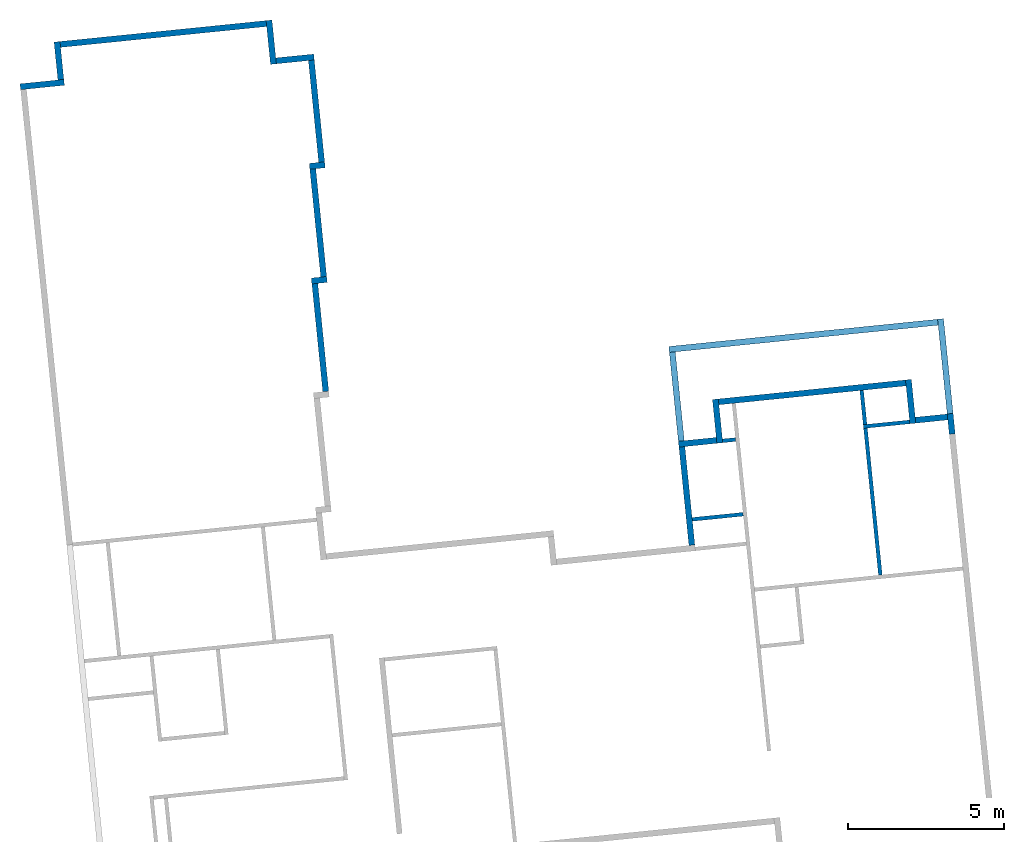
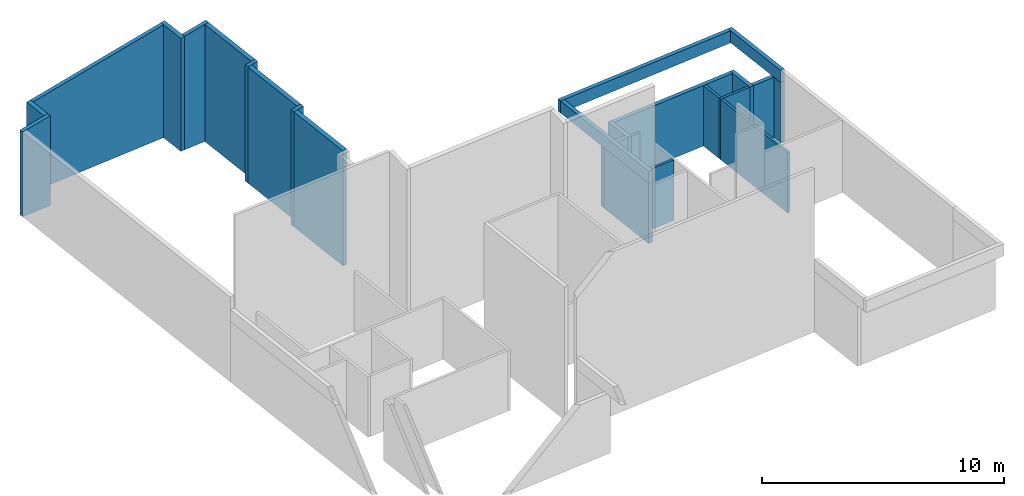
# One storey, part 2 of 2: 25 walls.
"""IFC2X3 building model written with IfcOpenShell, lengths in feet."""

from ifc_helpers import new_model, entity, si_unit, converted_unit, derived_unit, direction, frame, frame_2d, origin, place, context, subcontext, project, spatial, polyline, rectangle, extrude, clip, bounded_halfspace, material, layer, layer_set, layer_usage, type_object, element, save


model = new_model("IFC2X3")

# Units and contexts
model_context = context("Model", 3, precision=0.0001, world=origin(), true_north=direction((0.100810849702482, 0.994905609885814)))
body_context = subcontext(model_context, "Body", "Model", "MODEL_VIEW")
ifc_project = project(units=[converted_unit("LENGTHUNIT", "FOOT", entity("IfcRatioMeasure", 0.3048), si_unit("LENGTHUNIT", "METRE"), dimensions=[1, 0, 0, 0, 0, 0, 0]), converted_unit("AREAUNIT", "SQUARE FOOT", entity("IfcRatioMeasure", 0.09290304), si_unit("AREAUNIT", "SQUARE_METRE"), dimensions=[2, 0, 0, 0, 0, 0, 0]), converted_unit("VOLUMEUNIT", "CUBIC FOOT", entity("IfcRatioMeasure", 0.028316846592), si_unit("VOLUMEUNIT", "CUBIC_METRE"), dimensions=[3, 0, 0, 0, 0, 0, 0]), converted_unit("PLANEANGLEUNIT", "DEGREE", entity("IfcRatioMeasure", 0.0174532925199433), si_unit("PLANEANGLEUNIT", "RADIAN"), dimensions=[0, 0, 0, 0, 0, 0, 0]), si_unit("MASSUNIT", "GRAM", prefix="KILO"), derived_unit("MASSDENSITYUNIT", [(si_unit("MASSUNIT", "GRAM", prefix="KILO"), 1), (si_unit("LENGTHUNIT", "METRE"), -3)]), si_unit("TIMEUNIT", "SECOND"), si_unit("FREQUENCYUNIT", "HERTZ"), si_unit("THERMODYNAMICTEMPERATUREUNIT", "DEGREE_CELSIUS"), derived_unit("THERMALTRANSMITTANCEUNIT", [(si_unit("MASSUNIT", "GRAM", prefix="KILO"), 1), (si_unit("THERMODYNAMICTEMPERATUREUNIT", "KELVIN"), -1), (si_unit("TIMEUNIT", "SECOND"), -3)]), derived_unit("VOLUMETRICFLOWRATEUNIT", [(si_unit("LENGTHUNIT", "METRE"), 3), (si_unit("TIMEUNIT", "SECOND"), -1)]), si_unit("ELECTRICCURRENTUNIT", "AMPERE"), si_unit("ELECTRICVOLTAGEUNIT", "VOLT"), si_unit("POWERUNIT", "WATT"), si_unit("FORCEUNIT", "NEWTON"), si_unit("ILLUMINANCEUNIT", "LUX"), si_unit("LUMINOUSFLUXUNIT", "LUMEN"), si_unit("LUMINOUSINTENSITYUNIT", "CANDELA"), derived_unit("USERDEFINED", [(si_unit("MASSUNIT", "GRAM", prefix="KILO"), -1), (si_unit("LENGTHUNIT", "METRE"), -2), (si_unit("TIMEUNIT", "SECOND"), 3), (si_unit("LUMINOUSFLUXUNIT", "LUMEN"), 1)]), derived_unit("LINEARVELOCITYUNIT", [(si_unit("LENGTHUNIT", "METRE"), 1), (si_unit("TIMEUNIT", "SECOND"), -1)]), si_unit("PRESSUREUNIT", "PASCAL"), derived_unit("USERDEFINED", [(si_unit("LENGTHUNIT", "METRE"), -2), (si_unit("MASSUNIT", "GRAM", prefix="KILO"), 1), (si_unit("TIMEUNIT", "SECOND"), -2)])], contexts=[model_context])

# Site, building, storey
site_placement = place(None, frame((124.447249452883, 13.3868691254093, 0.0), z_axis=(0.0, 0.0, 1.0), x_axis=(0.994905609885814, 0.100810849702482, 0.0)))
site = spatial("IfcSite", under=ifc_project, at=site_placement, CompositionType="ELEMENT")
building_placement = place(site_placement, origin())
building = spatial("IfcBuilding", under=site, at=building_placement, CompositionType="ELEMENT")
storey_placement = place(building_placement, origin())
storey = spatial("IfcBuildingStorey", under=building, at=storey_placement, Name="First Floor", CompositionType="ELEMENT", Elevation=0.0)

# Walls
ifc_material_1 = material(Name="Stucco")
ifc_layer_1 = layer(ifc_material_1, 0.0729166666666667)
ifc_material_2 = material(Name="Plywood, Sheathing")
ifc_layer_2 = layer(ifc_material_2, 0.0416666666666667)
ifc_material_3 = material(Name="Softwood, Lumber")
ifc_layer_3 = layer(ifc_material_3, 0.458333333333333)
ifc_material_4 = material(Name="Gypsum Wall Board")
ifc_layer_4 = layer(ifc_material_4, 0.0520833333333333)
ifc_layer_set_1 = layer_set([ifc_layer_1, ifc_layer_2, ifc_layer_3, ifc_layer_4])
ifc_layer_usage_1 = layer_usage(ifc_layer_set_1, "AXIS2", "NEGATIVE", 0.3125)
wall_type_1 = type_object("IfcWallType", PredefinedType="STANDARD", material=ifc_layer_set_1)
wall_1_placement = place(storey_placement, frame((-30.5287863546898, -65.576981392437, 0.0)))
element("IfcWallStandardCase", 1, at=wall_1_placement, inside=storey, type_object=wall_type_1, material=ifc_layer_usage_1, Name="Basic Wall:Exterior - Stucco (light) on Wood Stud", context=body_context, shape_type="Clipping", body=[
    clip(extrude(rectangle(XDim=4.62500000000005, YDim=0.625, at=frame_2d((2.31250000000003, 1.11022302462516e-15), x_axis=(-1.0, 0.0))), origin(), (0.0, 0.0, 1.0), 14.8155898172751), bounded_halfspace(frame((0.0, -0.3125, 14.0000775315002), z_axis=(0.173648177666572, 0.0, -0.984807753012271), x_axis=(0.0, -1.0, 0.0)), True, frame((0.0, -0.3125, 14.0000775315002)), polyline([(0.0, 0.0), (0.625, 0.0), (4.62500000000005, 0.0), (4.62500000000005, 0.625000000000014), (4.0, 0.625), (0.0, 0.625), (0.0, 0.0)]))),
])
ifc_layer_usage_2 = layer_usage(ifc_layer_set_1, "AXIS2", "NEGATIVE", 0.3125)
wall_2_placement = place(storey_placement, frame((-26.2162863546897, -65.264481392437, 0.0), z_axis=(0.0, 0.0, 1.0), x_axis=(0.0, 1.0, 0.0)))
element("IfcWallStandardCase", 2, at=wall_2_placement, inside=storey, type_object=wall_type_1, material=ifc_layer_usage_2, Name="Basic Wall:Exterior - Stucco (light) on Wood Stud", context=body_context, shape_type="Clipping", body=[
    clip(extrude(rectangle(XDim=4.0, YDim=0.625, at=frame_2d((2.0, 0.0), x_axis=(-1.0, 0.0))), origin(), (0.0, 0.0, 1.0), 14.8155898172752), bounded_halfspace(frame((0.0, -0.3125, 14.8155898172751), z_axis=(0.0, -0.173648177666572, -0.984807753012271), x_axis=(-1.0, 0.0, 0.0)), True, frame((0.0, -0.3125, 14.8155898172751)), polyline([(0.0, 0.0), (3.375, 0.0), (4.0, 0.0), (4.0, 0.625), (0.0, 0.625), (0.0, 0.0)]))),
])
ifc_layer_usage_3 = layer_usage(ifc_layer_set_1, "AXIS2", "NEGATIVE", 0.3125)
wall_3_placement = place(storey_placement, frame((-3.84128635468974, -61.2644813924371, 0.0), z_axis=(0.0, 0.0, 1.0), x_axis=(0.0, -1.0, 0.0)))
element("IfcWallStandardCase", 3, at=wall_3_placement, inside=storey, type_object=wall_type_1, material=ifc_layer_usage_3, Name="Basic Wall:Exterior - Stucco (light) on Wood Stud", context=body_context, shape_type="Clipping", body=[
    clip(extrude(rectangle(XDim=4.62500000000001, YDim=0.625, at=frame_2d((2.31250000000001, 0.0), x_axis=(-1.0, 0.0))), origin(), (0.0, 0.0, 1.0), 18.7609060106187), bounded_halfspace(frame((0.0, -0.3125, 18.6507016476762), z_axis=(0.0, 0.173648177666572, -0.984807753012271), x_axis=(1.0, 0.0, 0.0)), True, frame((0.0, -0.3125, 18.6507016476762)), polyline([(0.0, 0.0), (0.625, 0.0), (4.62500000000001, 0.0), (4.62500000000001, 0.625), (4.0, 0.625), (0.0, 0.625), (0.0, 0.0)]))),
])
ifc_layer_usage_4 = layer_usage(ifc_layer_set_1, "AXIS2", "NEGATIVE", 0.3125)
wall_4_placement = place(storey_placement, frame((-3.52878635468974, -65.5769813924371, 0.0)))
element("IfcWallStandardCase", 4, at=wall_4_placement, inside=storey, type_object=wall_type_1, material=ifc_layer_usage_4, Name="Basic Wall:Exterior - Stucco (light) on Wood Stud", context=body_context, shape_type="Clipping", body=[
    clip(extrude(rectangle(XDim=4.0, YDim=0.625, at=frame_2d((2.0, 0.0), x_axis=(-1.0, 0.0))), origin(), (0.0, 0.0, 1.0), 19.466213933451), bounded_halfspace(frame((0.0, -0.3125, 18.7609060106186), z_axis=(0.173648177666572, 0.0, -0.984807753012271), x_axis=(0.0, -1.0, 0.0)), True, frame((0.0, -0.3125, 18.7609060106186)), polyline([(0.0, 0.0), (3.375, 0.0), (4.0, 0.0), (4.0, 0.625), (0.0, 0.625), (0.0, 0.0)]))),
])
ifc_layer_usage_5 = layer_usage(ifc_layer_set_1, "AXIS2", "NEGATIVE", 0.3125)
wall_5_placement = place(storey_placement, frame((0.158713645310257, -65.8894813924371, 0.0), z_axis=(0.0, 0.0, 1.0), x_axis=(0.0, -1.0, 0.0)))
element("IfcWallStandardCase", 5, at=wall_5_placement, inside=storey, type_object=wall_type_1, material=ifc_layer_usage_5, Name="Basic Wall:Exterior - Stucco (light) on Wood Stud", context=body_context, shape_type="Clipping", body=[
    clip(extrude(rectangle(XDim=10.75, YDim=0.625, at=frame_2d((5.375, 0.0), x_axis=(-1.0, 0.0))), origin(), (0.0, 0.0, 1.0), 19.466213933451), bounded_halfspace(frame((0.0, -0.3125, 19.3560095705084), z_axis=(0.0, 0.173648177666572, -0.984807753012271), x_axis=(1.0, 0.0, 0.0)), True, frame((0.0, -0.3125, 19.3560095705084)), polyline([(0.0, 0.0), (10.75, 0.0), (10.75, 0.625), (0.0, 0.625), (0.0, 0.0)]))),
])
ifc_layer_usage_6 = layer_usage(ifc_layer_set_1, "AXIS2", "NEGATIVE", 0.3125)
wall_6_placement = place(storey_placement, frame((0.471213645310257, -76.9519813924371, 0.0), z_axis=(0.0, 0.0, 1.0), x_axis=(-1.0, 0.0, 0.0)))
element("IfcWallStandardCase", 6, at=wall_6_placement, inside=storey, type_object=wall_type_1, material=ifc_layer_usage_6, Name="Basic Wall:Exterior - Stucco (light) on Wood Stud", context=body_context, shape_type="Clipping", body=[
    clip(extrude(rectangle(XDim=1.625, YDim=0.625, at=frame_2d((0.8125, 0.0), x_axis=(-1.0, 0.0))), origin(), (0.0, 0.0, 1.0), 19.4662139334508), bounded_halfspace(frame((0.0, -0.3125, 19.4662139334508), z_axis=(-0.173648177666572, 0.0, -0.984807753012271), x_axis=(0.0, 1.0, 0.0)), True, frame((0.0, -0.3125, 19.4662139334508)), polyline([(0.0, 0.0), (0.625, 0.0), (1.625, 0.0), (1.625, 0.625), (1.0, 0.625), (0.0, 0.625), (0.0, 0.0)]))),
])
ifc_layer_usage_7 = layer_usage(ifc_layer_set_1, "AXIS2", "NEGATIVE", 0.3125)
wall_7_placement = place(storey_placement, frame((-0.841286354689743, -77.2644813924371, 0.0), z_axis=(0.0, 0.0, 1.0), x_axis=(0.0, -1.0, 0.0)))
element("IfcWallStandardCase", 7, at=wall_7_placement, inside=storey, type_object=wall_type_1, material=ifc_layer_usage_7, Name="Basic Wall:Exterior - Stucco (light) on Wood Stud", context=body_context, shape_type="Clipping", body=[
    clip(extrude(rectangle(XDim=11.375, YDim=0.625, at=frame_2d((5.6875, 0.0), x_axis=(-1.0, 0.0))), origin(), (0.0, 0.0, 1.0), 19.2898869527427), bounded_halfspace(frame((0.0, -0.3125, 19.1796825898002), z_axis=(0.0, 0.173648177666572, -0.984807753012271), x_axis=(1.0, 0.0, 0.0)), True, frame((0.0, -0.3125, 19.1796825898002)), polyline([(0.0, 0.0), (11.375, 0.0), (11.375, 0.625), (0.0, 0.625), (0.0, 0.0)]))),
])
ifc_layer_usage_8 = layer_usage(ifc_layer_set_1, "AXIS2", "NEGATIVE", 0.3125)
wall_8_placement = place(storey_placement, frame((-0.528786354689743, -88.9519813924371, 0.0), z_axis=(0.0, 0.0, 1.0), x_axis=(-1.0, 0.0, 0.0)))
element("IfcWallStandardCase", 8, at=wall_8_placement, inside=storey, type_object=wall_type_1, material=ifc_layer_usage_8, Name="Basic Wall:Exterior - Stucco (light) on Wood Stud", context=body_context, shape_type="Clipping", body=[
    clip(extrude(rectangle(XDim=1.625, YDim=0.625, at=frame_2d((0.8125, 0.0), x_axis=(-1.0, 0.0))), origin(), (0.0, 0.0, 1.0), 19.2898869527425), bounded_halfspace(frame((0.0, -0.3125, 19.2898869527425), z_axis=(-0.173648177666572, 0.0, -0.984807753012271), x_axis=(0.0, 1.0, 0.0)), True, frame((0.0, -0.3125, 19.2898869527425)), polyline([(0.0, 0.0), (0.625, 0.0), (1.625, 0.0), (1.625, 0.625), (1.0, 0.625), (0.0, 0.625), (0.0, 0.0)]))),
])
ifc_layer_usage_9 = layer_usage(ifc_layer_set_1, "AXIS2", "NEGATIVE", 0.3125)
wall_9_placement = place(storey_placement, frame((-1.84128635468974, -89.2644813924371, 0.0), z_axis=(0.0, 0.0, 1.0), x_axis=(0.0, -1.0, 0.0)))
element("IfcWallStandardCase", 9, at=wall_9_placement, inside=storey, type_object=wall_type_1, material=ifc_layer_usage_9, Name="Basic Wall:Exterior - Stucco (light) on Wood Stud", context=body_context, shape_type="Clipping", body=[
    clip(extrude(rectangle(XDim=11.375, YDim=0.625, at=frame_2d((5.6875, 0.0), x_axis=(-1.0, 0.0))), origin(), (0.0, 0.0, 1.0), 19.1135599720344), bounded_halfspace(frame((0.0, -0.3125, 19.0033556090919), z_axis=(0.0, 0.173648177666572, -0.984807753012271), x_axis=(1.0, 0.0, 0.0)), True, frame((0.0, -0.3125, 19.0033556090919)), polyline([(0.0, 0.0), (11.375, 0.0), (11.375, 0.625), (0.0, 0.625), (0.0, 0.0)]))),
])
ifc_layer_usage_10 = layer_usage(ifc_layer_set_1, "AXIS2", "NEGATIVE", 0.3125)
wall_10_placement = place(storey_placement, frame((38.7836969786436, -110.201981392437, 0.0), z_axis=(0.0, 0.0, 1.0), x_axis=(0.0, 1.0, 0.0)))
element("IfcWallStandardCase", 10, at=wall_10_placement, inside=storey, type_object=wall_type_1, material=ifc_layer_usage_10, Name="Basic Wall:Exterior - Stucco (light) on Wood Stud", context=body_context, shape_type="SweptSolid", body=[
    extrude(rectangle(XDim=4.625, YDim=0.625, at=frame_2d((2.3125, 0.0), x_axis=(-1.0, 0.0))), origin(), (0.0, 0.0, 1.0), 10.0),
])
ifc_layer_usage_11 = layer_usage(ifc_layer_set_1, "AXIS2", "NEGATIVE", 0.3125)
wall_11_placement = place(storey_placement, frame((59.1587136453103, -105.576981392437, 0.0), z_axis=(0.0, 0.0, 1.0), x_axis=(0.0, -1.0, 0.0)))
element("IfcWallStandardCase", 11, at=wall_11_placement, inside=storey, type_object=wall_type_1, material=ifc_layer_usage_11, Name="Basic Wall:Exterior - Stucco (light) on Wood Stud", context=body_context, shape_type="SweptSolid", body=[
    extrude(rectangle(XDim=4.62499999999999, YDim=0.625, at=frame_2d((2.31249999999999, 5.55111512312578e-16), x_axis=(-1.0, 0.0))), origin(), (0.0, 0.0, 1.0), 10.0),
])
ifc_layer_usage_12 = layer_usage(ifc_layer_set_1, "AXIS2", "NEGATIVE", 0.3125)
wall_12_placement = place(storey_placement, frame((-25.9037863546897, -61.576981392437, 0.0)))
element("IfcWallStandardCase", 12, at=wall_12_placement, inside=storey, type_object=wall_type_1, material=ifc_layer_usage_12, Name="Basic Wall:Exterior - Stucco (light) on Wood Stud", context=body_context, shape_type="Clipping", body=[
    clip(extrude(rectangle(XDim=21.75, YDim=0.625, at=frame_2d((10.875, -1.94289029309402e-15), x_axis=(-1.0, 0.0))), origin(), (0.0, 0.0, 1.0), 18.6507016476762), bounded_halfspace(frame((0.0, -0.3125, 14.8155898172752), z_axis=(0.173648177666572, 0.0, -0.984807753012271), x_axis=(0.0, -1.0, 0.0)), True, frame((0.0, -0.3125, 14.8155898172752)), polyline([(0.0, 0.0), (21.75, 0.0), (21.75, 0.624999999999993), (0.0, 0.625), (0.0, 0.0)]))),
])
ifc_layer_usage_13 = layer_usage(ifc_layer_set_1, "AXIS2", "NEGATIVE", 0.3125)
wall_13_placement = place(storey_placement, frame((34.4711969786436, -109.889481392437, 0.0)))
element("IfcWallStandardCase", 13, at=wall_13_placement, inside=storey, type_object=wall_type_1, material=ifc_layer_usage_13, Name="Basic Wall:Exterior - Stucco (light) on Wood Stud", context=body_context, shape_type="SweptSolid", body=[
    extrude(rectangle(XDim=3.99999999999999, YDim=0.625, at=frame_2d((2.0, 0.0), x_axis=(-1.0, 0.0))), origin(), (0.0, 0.0, 1.0), 10.0),
])
ifc_layer_usage_14 = layer_usage(ifc_layer_set_1, "AXIS2", "NEGATIVE", 0.3125)
wall_14_placement = place(storey_placement, frame((39.0961969786436, -105.889481392437, 0.0)))
element("IfcWallStandardCase", 14, at=wall_14_placement, inside=storey, type_object=wall_type_1, material=ifc_layer_usage_14, Name="Basic Wall:Exterior - Stucco (light) on Wood Stud", context=body_context, shape_type="SweptSolid", body=[
    extrude(rectangle(XDim=19.7500166666667, YDim=0.625, at=frame_2d((9.87500833333333, -2.1094237467878e-15), x_axis=(-1.0, 0.0))), origin(), (0.0, 0.0, 1.0), 10.0),
])
ifc_layer_usage_15 = layer_usage(ifc_layer_set_1, "AXIS2", "NEGATIVE", 0.3125)
wall_15_placement = place(storey_placement, frame((59.4712136453103, -109.889481392437, 0.0)))
element("IfcWallStandardCase", 15, at=wall_15_placement, inside=storey, type_object=wall_type_1, material=ifc_layer_usage_15, Name="Basic Wall:Exterior - Stucco (light) on Wood Stud", context=body_context, shape_type="SweptSolid", body=[
    extrude(rectangle(XDim=3.375, YDim=0.625, at=frame_2d((1.6875, -2.27595720048157e-15), x_axis=(-1.0, 0.0))), origin(), (0.0, 0.0, 1.0), 10.0),
])
ifc_layer_usage_16 = layer_usage(ifc_layer_set_1, "AXIS2", "POSITIVE", -0.3125)
wall_16_placement = place(storey_placement, frame((34.7836969786436, -110.201981392437, 0.0), z_axis=(0.0, 0.0, 1.0), x_axis=(0.0, -1.0, 0.0)))
element("IfcWallStandardCase", 16, at=wall_16_placement, inside=storey, type_object=wall_type_1, material=ifc_layer_usage_16, Name="Basic Wall:Exterior - Stucco (light) on Wood Stud", context=body_context, shape_type="SweptSolid", body=[
    extrude(rectangle(XDim=10.375, YDim=0.625, at=frame_2d((5.1875, -2.80331313717852e-15), x_axis=(-1.0, 0.0))), origin(), (0.0, 0.0, 1.0), 10.0),
])
ifc_layer_usage_17 = layer_usage(ifc_layer_set_1, "AXIS2", "NEGATIVE", 0.3125)
wall_17_placement = place(storey_placement, frame((63.1587136453103, -109.576981392437, 0.0), z_axis=(0.0, 0.0, 1.0), x_axis=(0.0, -1.0, 0.0)))
element("IfcWallStandardCase", 17, at=wall_17_placement, inside=storey, type_object=wall_type_1, material=ifc_layer_usage_17, Name="Basic Wall:Exterior - Stucco (light) on Wood Stud", context=body_context, shape_type="SweptSolid", body=[
    extrude(rectangle(XDim=2.15104166666663, YDim=0.625, at=frame_2d((1.07552083333331, 0.0), x_axis=(-1.0, 0.0))), origin(), (0.0, 0.0, 1.0), 10.0),
])
ifc_material_5 = material(Name="Stucco - Black")
ifc_layer_5 = layer(ifc_material_5, 0.0729166666666667)
ifc_layer_6 = layer(ifc_material_2, 0.0416666666666667)
ifc_layer_7 = layer(ifc_material_3, 0.458333333333333)
ifc_layer_8 = layer(ifc_material_4, 0.0520833333333333)
ifc_layer_set_2 = layer_set([ifc_layer_5, ifc_layer_6, ifc_layer_7, ifc_layer_8])
ifc_layer_usage_18 = layer_usage(ifc_layer_set_2, "AXIS2", "POSITIVE", -0.3125)
wall_type_2 = type_object("IfcWallType", PredefinedType="STANDARD", material=ifc_layer_set_2)
wall_18_placement = place(storey_placement, frame((63.1587136453103, -111.728023059104, 10.0), z_axis=(0.0, 0.0, 1.0), x_axis=(0.0, 1.0, 0.0)))
element("IfcWallStandardCase", 18, at=wall_18_placement, inside=storey, type_object=wall_type_2, material=ifc_layer_usage_18, Name="Basic Wall:Exterior - Stucco (dark) on Wood Stud", context=body_context, shape_type="SweptSolid", body=[
    extrude(rectangle(XDim=12.1510416666666, YDim=0.625, at=frame_2d((6.07552083333332, 1.60982338570648e-15), x_axis=(-1.0, 0.0))), origin(), (0.0, 0.0, 1.0), 2.0),
])
ifc_layer_usage_19 = layer_usage(ifc_layer_set_2, "AXIS2", "POSITIVE", -0.3125)
wall_19_placement = place(storey_placement, frame((62.8462136453103, -99.8894813924372, 10.0), z_axis=(0.0, 0.0, 1.0), x_axis=(-1.0, 0.0, 0.0)))
element("IfcWallStandardCase", 19, at=wall_19_placement, inside=storey, type_object=wall_type_2, material=ifc_layer_usage_19, Name="Basic Wall:Exterior - Stucco (dark) on Wood Stud", context=body_context, shape_type="SweptSolid", body=[
    extrude(rectangle(XDim=28.3750166666667, YDim=0.625, at=frame_2d((14.1875083333333, 0.0), x_axis=(-1.0, 0.0))), origin(), (0.0, 0.0, 1.0), 2.0),
])
ifc_layer_usage_20 = layer_usage(ifc_layer_set_2, "AXIS2", "POSITIVE", -0.3125)
wall_20_placement = place(storey_placement, frame((34.7836969786436, -100.201981392437, 10.0), z_axis=(0.0, 0.0, 1.0), x_axis=(0.0, -1.0, 0.0)))
element("IfcWallStandardCase", 20, at=wall_20_placement, inside=storey, type_object=wall_type_2, material=ifc_layer_usage_20, Name="Basic Wall:Exterior - Stucco (dark) on Wood Stud", context=body_context, shape_type="SweptSolid", body=[
    extrude(rectangle(XDim=20.3749999999999, YDim=0.625, at=frame_2d((10.1875, -7.49400541621981e-16), x_axis=(-1.0, 0.0))), origin(), (0.0, 0.0, 1.0), 2.0),
])
ifc_layer_9 = layer(ifc_material_4, 0.0520833333333333)
ifc_layer_10 = layer(ifc_material_3, 0.291666666666667)
ifc_layer_11 = layer(ifc_material_4, 0.0520833333333333)
ifc_layer_set_3 = layer_set([ifc_layer_9, ifc_layer_10, ifc_layer_11])
ifc_layer_usage_21 = layer_usage(ifc_layer_set_3, "AXIS2", "NEGATIVE", 0.197916666666667)
wall_type_3 = type_object("IfcWallType", PredefinedType="STANDARD", material=ifc_layer_set_3)
wall_21_placement = place(storey_placement, frame((58.8462136453103, -110.004064725771, 0.0), z_axis=(0.0, 0.0, 1.0), x_axis=(-1.0, 0.0, 0.0)))
element("IfcWallStandardCase", 21, at=wall_21_placement, inside=storey, type_object=wall_type_3, material=ifc_layer_usage_21, context=body_context, shape_type="SweptSolid", body=[
    extrude(rectangle(XDim=4.88541666666666, YDim=0.395833333333343, at=frame_2d((2.44270833333333, 2.1094237467878e-15), x_axis=(-1.0, 0.0))), origin(), (0.0, 0.0, 1.0), 10.0),
])
ifc_layer_usage_22 = layer_usage(ifc_layer_set_3, "AXIS2", "NEGATIVE", 0.197916666666667)
wall_22_placement = place(storey_placement, frame((54.1587136453103, -109.806148059104, 0.0), z_axis=(0.0, 0.0, 1.0), x_axis=(0.0, 1.0, 0.0)))
element("IfcWallStandardCase", 22, at=wall_22_placement, inside=storey, type_object=wall_type_3, material=ifc_layer_usage_22, context=body_context, shape_type="SweptSolid", body=[
    extrude(rectangle(XDim=3.60416666666667, YDim=0.395833333333329, at=frame_2d((1.80208333333334, -3.46944695195361e-16), x_axis=(-1.0, 0.0))), origin(), (0.0, 0.0, 1.0), 10.0),
])
ifc_layer_usage_23 = layer_usage(ifc_layer_set_3, "AXIS2", "NEGATIVE", 0.197916666666667)
wall_23_placement = place(storey_placement, frame((54.1587136453103, -110.201981392437, 0.0), z_axis=(0.0, 0.0, 1.0), x_axis=(0.0, -1.0, 0.0)))
element("IfcWallStandardCase", 23, at=wall_23_placement, inside=storey, type_object=wall_type_3, material=ifc_layer_usage_23, context=body_context, shape_type="SweptSolid", body=[
    extrude(rectangle(XDim=15.4895833333333, YDim=0.395833333333329, at=frame_2d((7.74479166666666, -4.44089209850063e-16), x_axis=(-1.0, 0.0))), origin(), (0.0, 0.0, 1.0), 10.0),
])
ifc_layer_usage_24 = layer_usage(ifc_layer_set_3, "AXIS2", "NEGATIVE", 0.197916666666667)
wall_24_placement = place(storey_placement, frame((40.4711969786436, -117.889481392437, 0.0), z_axis=(0.0, 0.0, 1.0), x_axis=(-1.0, 0.0, 0.0)))
element("IfcWallStandardCase", 24, at=wall_24_placement, inside=storey, type_object=wall_type_3, material=ifc_layer_usage_24, context=body_context, shape_type="SweptSolid", body=[
    extrude(rectangle(XDim=5.37499999999998, YDim=0.395833333333343, at=frame_2d((2.68749999999999, -1.66533453693773e-16), x_axis=(-1.0, 0.0))), origin(), (0.0, 0.0, 1.0), 10.0),
])
ifc_layer_usage_25 = layer_usage(ifc_layer_set_3, "AXIS2", "NEGATIVE", 0.197916666666667)
wall_25_placement = place(storey_placement, frame((39.0961969786436, -110.00406472577, 0.0)))
element("IfcWallStandardCase", 25, at=wall_25_placement, inside=storey, type_object=wall_type_3, material=ifc_layer_usage_25, context=body_context, shape_type="SweptSolid", body=[
    extrude(rectangle(XDim=1.37499999999999, YDim=0.395833333333343, at=frame_2d((0.687499999999993, 0.0), x_axis=(-1.0, 0.0))), origin(), (0.0, 0.0, 1.0), 10.0),
])

save(model, "model.ifc")
